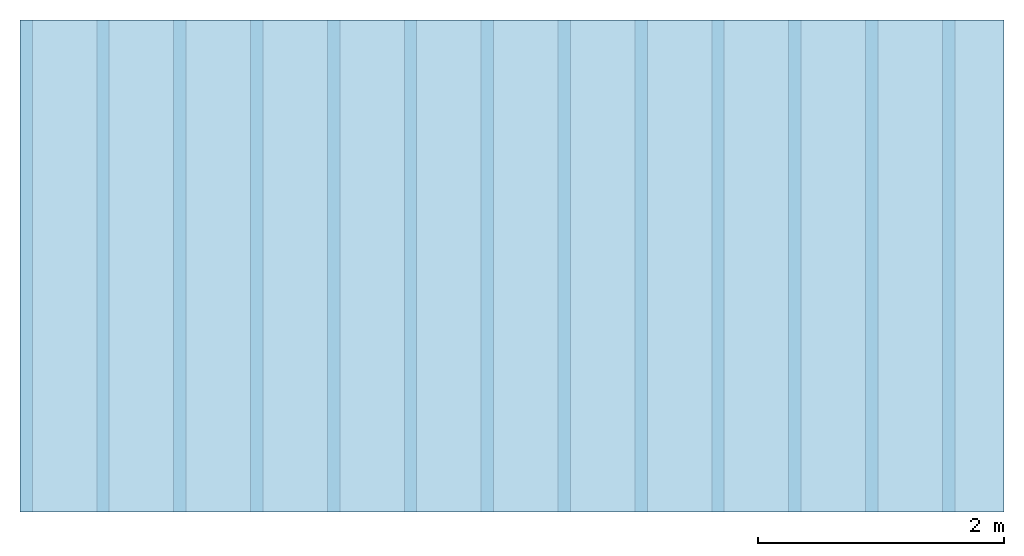
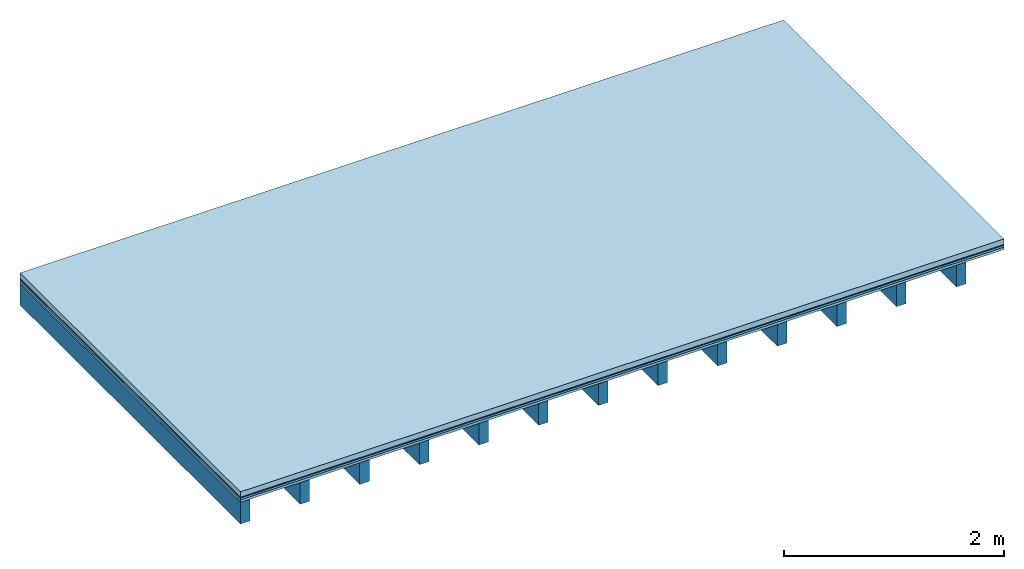
# One storey: 4 plates, 1 member, 1 element without a shape of its own.
"""IFC4 building model written with IfcOpenShell, lengths in metres."""

from ifc_helpers import new_model, si_unit, derived_unit, direction, frame, frame_2d, origin, origin_with_axes, place, context, project, spatial, rectangle, extrude, material, layer, layer_set, type_object, element, aggregate, save


model = new_model("IFC4")

# Units and contexts
plan_context = context("Plan", 3, precision=1e-05, world=origin(), true_north=direction((0.0, 1.0)))
model_context = context("Model", 3, precision=1e-05, world=origin(), true_north=direction((0.0, 1.0)))
ifc_project = project(units=[si_unit("LENGTHUNIT", "METRE"), derived_unit("SOUNDPRESSUREUNIT", [(si_unit("PRESSUREUNIT", "PASCAL", prefix="MICRO"), 0)]), si_unit("ENERGYUNIT", "JOULE", prefix="MEGA"), si_unit("MASSUNIT", "GRAM", prefix="KILO"), derived_unit("THERMALTRANSMITTANCEUNIT", [(si_unit("POWERUNIT", "WATT"), 1), (si_unit("AREAUNIT", "SQUARE_METRE"), -1), (si_unit("THERMODYNAMICTEMPERATUREUNIT", "KELVIN"), -1)]), derived_unit("AREADENSITYUNIT", [(si_unit("MASSUNIT", "GRAM", prefix="KILO"), 1), (si_unit("AREAUNIT", "SQUARE_METRE"), -1)]), derived_unit("USERDEFINED", [(si_unit("ENERGYUNIT", "JOULE", prefix="MEGA"), 1), (si_unit("AREAUNIT", "SQUARE_METRE"), -1)])], contexts=[plan_context, model_context])

# Site, building, storey
site = spatial("IfcSite", under=ifc_project)
building_placement = place(None, origin())
building = spatial("IfcBuilding", under=site, at=building_placement)
storey_placement = place(building_placement, origin())
storey = spatial("IfcBuildingStorey", under=building, at=storey_placement)

# Slab, member, plates
ifc_material_1 = material(Name="clay", Category="02.004")
ifc_layer_1 = layer(ifc_material_1, 0.06, Name="Use and protection layer 2")
ifc_material_2 = material(Name="Protective layer", Category="09.007")
ifc_layer_2 = layer(ifc_material_2, 0.01, Name="Use and protection layer 1")
ifc_material_3 = material(Name="Bituminous", Category="09.003")
ifc_layer_3 = layer(ifc_material_3, 0.02, Name="Seal")
ifc_material_4 = material(Name="3-layer panels", Category="07.001")
ifc_layer_4 = layer(ifc_material_4, 0.027, Name="above 2nd layer")
ifc_material_5 = material(Name="no composite action")
ifc_layer_5 = layer(ifc_material_5, 0.0, Name="Bond")
ifc_layer_6 = layer(None, 0.24, Name="Support")
ifc_layer_set = layer_set([ifc_layer_1, ifc_layer_2, ifc_layer_3, ifc_layer_4, ifc_layer_5, ifc_layer_6])
slab_type = type_object("IfcSlabType", Name="F0098", PredefinedType="NOTDEFINED", material=ifc_layer_set)
slab_placement = place(None, frame((0.0, 0.0, 0.0), z_axis=(0.0, 0.0, -1.0), x_axis=(1.0, 0.0, 0.0)))
slab = element("IfcSlab", 1, at=slab_placement, inside=storey, type_object=slab_type, material=ifc_layer_set, Name="Slab #1")
ifc_material_6 = material()
member_placement = place(slab_placement, origin())
member = element("IfcMember", 2, at=member_placement, material=ifc_material_6, Name="Support", context=plan_context, shape_type="SweptSolid", body=[
    extrude(rectangle(XDim=0.1, YDim=0.24, at=frame_2d((0.05, 0.12), x_axis=(1.0, 0.0))), frame((0.0, 4.0, 0.117), z_axis=(0.0, -1.0, 0.0), x_axis=(1.0, 0.0, 0.0)), (0.0, 0.0, 1.0), 4.0),
    extrude(rectangle(XDim=0.1, YDim=0.24, at=frame_2d((0.05, 0.12), x_axis=(1.0, 0.0))), frame((0.625, 4.0, 0.117), z_axis=(0.0, -1.0, 0.0), x_axis=(1.0, 0.0, 0.0)), (0.0, 0.0, 1.0), 4.0),
    extrude(rectangle(XDim=0.1, YDim=0.24, at=frame_2d((0.05, 0.12), x_axis=(1.0, 0.0))), frame((1.25, 4.0, 0.117), z_axis=(0.0, -1.0, 0.0), x_axis=(1.0, 0.0, 0.0)), (0.0, 0.0, 1.0), 4.0),
    extrude(rectangle(XDim=0.1, YDim=0.24, at=frame_2d((0.05, 0.12), x_axis=(1.0, 0.0))), frame((1.875, 4.0, 0.117), z_axis=(0.0, -1.0, 0.0), x_axis=(1.0, 0.0, 0.0)), (0.0, 0.0, 1.0), 4.0),
    extrude(rectangle(XDim=0.1, YDim=0.24, at=frame_2d((0.05, 0.12), x_axis=(1.0, 0.0))), frame((2.5, 4.0, 0.117), z_axis=(0.0, -1.0, 0.0), x_axis=(1.0, 0.0, 0.0)), (0.0, 0.0, 1.0), 4.0),
    extrude(rectangle(XDim=0.1, YDim=0.24, at=frame_2d((0.05, 0.12), x_axis=(1.0, 0.0))), frame((3.125, 4.0, 0.117), z_axis=(0.0, -1.0, 0.0), x_axis=(1.0, 0.0, 0.0)), (0.0, 0.0, 1.0), 4.0),
    extrude(rectangle(XDim=0.1, YDim=0.24, at=frame_2d((0.05, 0.12), x_axis=(1.0, 0.0))), frame((3.75, 4.0, 0.117), z_axis=(0.0, -1.0, 0.0), x_axis=(1.0, 0.0, 0.0)), (0.0, 0.0, 1.0), 4.0),
    extrude(rectangle(XDim=0.1, YDim=0.24, at=frame_2d((0.05, 0.12), x_axis=(1.0, 0.0))), frame((4.375, 4.0, 0.117), z_axis=(0.0, -1.0, 0.0), x_axis=(1.0, 0.0, 0.0)), (0.0, 0.0, 1.0), 4.0),
    extrude(rectangle(XDim=0.1, YDim=0.24, at=frame_2d((0.05, 0.12), x_axis=(1.0, 0.0))), frame((5.0, 4.0, 0.117), z_axis=(0.0, -1.0, 0.0), x_axis=(1.0, 0.0, 0.0)), (0.0, 0.0, 1.0), 4.0),
    extrude(rectangle(XDim=0.1, YDim=0.24, at=frame_2d((0.05, 0.12), x_axis=(1.0, 0.0))), frame((5.625, 4.0, 0.117), z_axis=(0.0, -1.0, 0.0), x_axis=(1.0, 0.0, 0.0)), (0.0, 0.0, 1.0), 4.0),
    extrude(rectangle(XDim=0.1, YDim=0.24, at=frame_2d((0.05, 0.12), x_axis=(1.0, 0.0))), frame((6.25, 4.0, 0.117), z_axis=(0.0, -1.0, 0.0), x_axis=(1.0, 0.0, 0.0)), (0.0, 0.0, 1.0), 4.0),
    extrude(rectangle(XDim=0.1, YDim=0.24, at=frame_2d((0.05, 0.12), x_axis=(1.0, 0.0))), frame((6.875, 4.0, 0.117), z_axis=(0.0, -1.0, 0.0), x_axis=(1.0, 0.0, 0.0)), (0.0, 0.0, 1.0), 4.0),
    extrude(rectangle(XDim=0.1, YDim=0.24, at=frame_2d((0.05, 0.12), x_axis=(1.0, 0.0))), frame((7.5, 4.0, 0.117), z_axis=(0.0, -1.0, 0.0), x_axis=(1.0, 0.0, 0.0)), (0.0, 0.0, 1.0), 4.0),
])
plate_1_placement = place(slab_placement, origin())
plate_1 = element("IfcPlate", 3, at=plate_1_placement, material=ifc_material_1, Name="Use and protection layer 2", context=plan_context, shape_type="SweptSolid", body=[
    extrude(rectangle(XDim=8.0, YDim=4.0, at=frame_2d((4.0, 2.0), x_axis=(1.0, 0.0))), origin_with_axes(), (0.0, 0.0, 1.0), 0.06),
])
plate_2_placement = place(slab_placement, origin())
plate_2 = element("IfcPlate", 4, at=plate_2_placement, material=ifc_material_2, Name="Use and protection layer 1", context=plan_context, shape_type="SweptSolid", body=[
    extrude(rectangle(XDim=8.0, YDim=4.0, at=frame_2d((4.0, 2.0), x_axis=(1.0, 0.0))), frame((0.0, 0.0, 0.06), z_axis=(0.0, 0.0, 1.0), x_axis=(1.0, 0.0, 0.0)), (0.0, 0.0, 1.0), 0.01),
])
plate_3_placement = place(slab_placement, origin())
plate_3 = element("IfcPlate", 5, at=plate_3_placement, material=ifc_material_3, Name="Seal", context=plan_context, shape_type="SweptSolid", body=[
    extrude(rectangle(XDim=8.0, YDim=4.0, at=frame_2d((4.0, 2.0), x_axis=(1.0, 0.0))), frame((0.0, 0.0, 0.07), z_axis=(0.0, 0.0, 1.0), x_axis=(1.0, 0.0, 0.0)), (0.0, 0.0, 1.0), 0.02),
])
plate_4_placement = place(slab_placement, origin())
plate_4 = element("IfcPlate", 6, at=plate_4_placement, material=ifc_material_4, Name="above 2nd layer", context=plan_context, shape_type="SweptSolid", body=[
    extrude(rectangle(XDim=8.0, YDim=4.0, at=frame_2d((4.0, 2.0), x_axis=(1.0, 0.0))), frame((0.0, 0.0, 0.09), z_axis=(0.0, 0.0, 1.0), x_axis=(1.0, 0.0, 0.0)), (0.0, 0.0, 1.0), 0.027),
])
aggregate(slab, [plate_1, plate_2, plate_3, plate_4, member])

save(model, "model.ifc")
